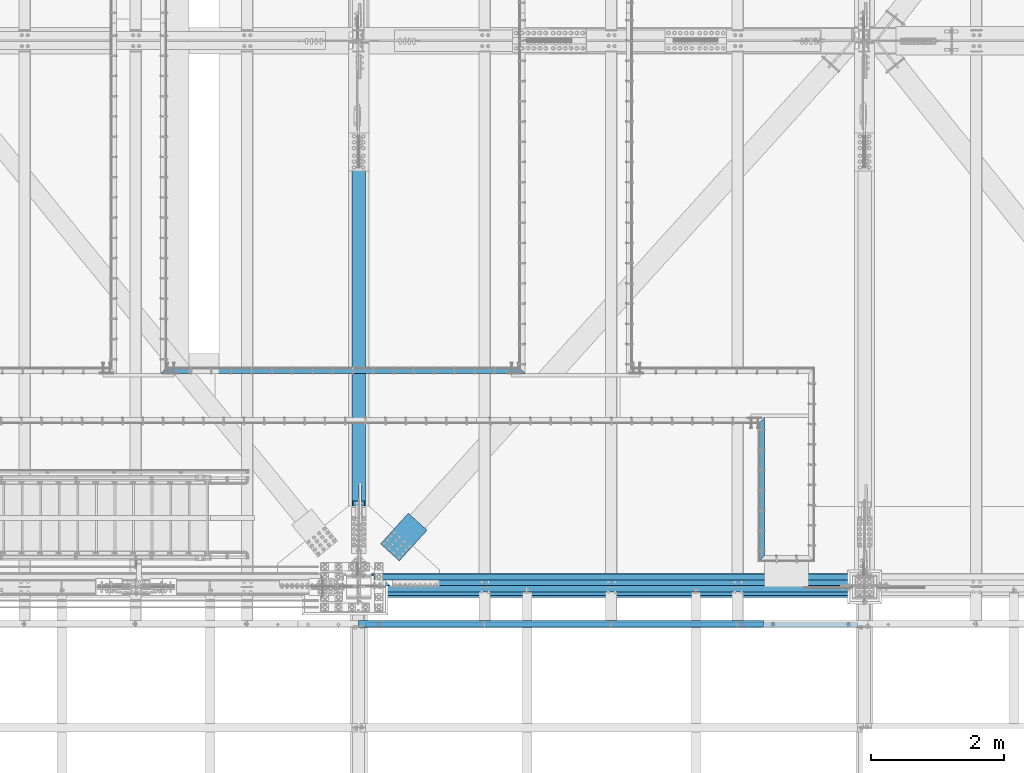
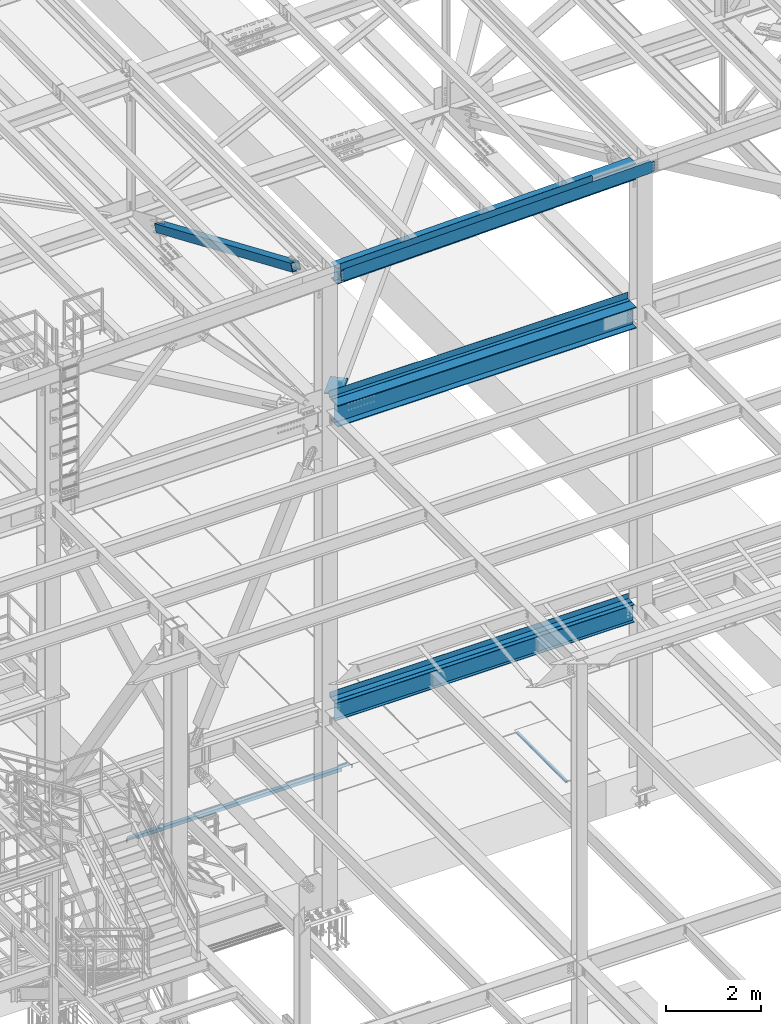
# One storey, part 1798 of 3843: 10 beams, 1 member, 9 elements without a shape of their own.
"""IFC2X3 building model written with IfcOpenShell, lengths in millimetres."""

from ifc_helpers import new_model, si_unit, frame, origin_with_axes, place, context, subcontext, project, spatial, faceted_brep, material, type_object, element, aggregate, save


model = new_model("IFC2X3")

# Units and contexts
model_context = context("Model", 3, precision=1e-05, world=origin_with_axes())
body_context = subcontext(model_context, "Body", "Model", "MODEL_VIEW")
ifc_project = project(units=[si_unit("LENGTHUNIT", "METRE", prefix="MILLI"), si_unit("AREAUNIT", "SQUARE_METRE"), si_unit("VOLUMEUNIT", "CUBIC_METRE"), si_unit("MASSUNIT", "GRAM", prefix="KILO"), si_unit("TIMEUNIT", "SECOND"), si_unit("PLANEANGLEUNIT", "RADIAN"), si_unit("SOLIDANGLEUNIT", "STERADIAN"), si_unit("THERMODYNAMICTEMPERATUREUNIT", "DEGREE_CELSIUS"), si_unit("LUMINOUSINTENSITYUNIT", "LUMEN")], contexts=[model_context])

# Site, building, storey
site_placement = place(None, origin_with_axes())
site = spatial("IfcSite", under=ifc_project, at=site_placement, CompositionType="ELEMENT")
building_placement = place(site_placement, origin_with_axes())
building = spatial("IfcBuilding", under=site, at=building_placement, Name="Undefined", CompositionType="ELEMENT")
storey_placement = place(building_placement, origin_with_axes())
storey = spatial("IfcBuildingStorey", under=building, at=storey_placement, Name="Undefined", CompositionType="ELEMENT", Elevation=0.0)

# Assembly, beam
assembly_1_placement = place(storey_placement, origin_with_axes())
assembly_1 = element("IfcElementAssembly", 1, at=assembly_1_placement, inside=storey, Name="EMBED_ANGLE", AssemblyPlace="NOTDEFINED", PredefinedType="RIGID_FRAME")
ifc_material_1 = material(Name="STEEL/A36")
beam_type_1 = type_object("IfcBeamType", Name="L3-1/2X3-1/2X5/16", PredefinedType="NOTDEFINED")
beam_1_placement = place(assembly_1_placement, frame((68707.7619595486, 26000.0749973387, 30410.15), z_axis=(0.0, 0.0, -1.0), x_axis=(0.0, 1.0, 0.0)))
beam_1 = element("IfcBeam", 2, at=beam_1_placement, type_object=beam_type_1, material=ifc_material_1, Name="EMBED_ANGLE", ObjectType="L3-1/2X3-1/2X5/16", context=body_context, shape_type="Brep", body=[
    faceted_brep([(88.8999999971129, 44.4500000000007, -44.4499999999971), (88.8999999965163, 44.4499999999971, 44.4500000000007), (2168.52499994361, 44.4499999956824, 44.4500000000007), (2168.52499994361, 44.4499999956824, -44.4500000000007), (80.9624999965163, 36.5124999999971, 44.4500000000007), (2160.58750050484, 36.5124999957043, 44.4500000000007), (80.9624999971129, 36.5125000000007, -36.5124999999971), (2160.58750050484, 36.5124999957043, -36.5125000000007), (3.63797880709171e-12, -44.4499999999971, -36.5125000000007), (2079.62500622933, -44.4500000041371, -36.5125000000007), (3.63797880709171e-12, -44.4499999999971, -44.4500000000007), (2079.62500622933, -44.4500000041371, -44.4500000000007)], [[[0, 1, 2, 3]], [[1, 4, 5, 2]], [[4, 6, 7, 5]], [[6, 8, 9, 7]], [[8, 10, 11, 9]], [[10, 0, 3, 11]], [[5, 7, 9, 11, 3, 2]], [[10, 8, 6, 4, 1, 0]]]),
])
aggregate(assembly_1, [beam_1])

assembly_2_placement = place(storey_placement, origin_with_axes())
assembly_2 = element("IfcElementAssembly", 3, at=assembly_2_placement, inside=storey, Name="EMBED_ANGLE", AssemblyPlace="NOTDEFINED", PredefinedType="RIGID_FRAME")
beam_2_placement = place(assembly_2_placement, frame((59652.662, 28873.45, 30410.15), z_axis=(0.0, 0.0, -1.0), x_axis=(1.0, 0.0, 0.0)))
beam_2 = element("IfcBeam", 4, at=beam_2_placement, type_object=beam_type_1, material=ifc_material_1, Name="EMBED_ANGLE", ObjectType="L3-1/2X3-1/2X5/16", context=body_context, shape_type="Brep", body=[
    faceted_brep([(44.4499023437311, 36.5125000000007, 44.4500000000007), (44.4499023437311, 36.5125000000007, -36.5125000000007), (44.4499023437311, 44.4500000000007, -36.5125000000007), (44.4499023437311, 44.4500000000007, 44.4500000000007), (260.349902343754, 36.5125000000007, -36.5125000000007), (260.349902343754, 44.4500000000007, -36.5125000000044), (260.349902343754, 36.5125000000007, 44.4499999999862), (260.349902343754, 44.4500000000007, 44.4500000000007), (5484.87605566408, 36.5125000000007, 44.4500000000007), (5492.81355566408, 44.4500000000007, 44.4500000000007), (5448.29999999998, 44.4500000000007, 44.4500000000007), (5448.29999999998, 36.5125000000007, 44.4499999999862), (5232.39999999996, 36.5125000000007, -36.5125000000007), (5232.39999999996, 36.5125000000007, 44.4500000000007), (5232.39999999996, 44.4500000000007, -36.5125000000007), (5232.39999999996, 44.4500000000007, 44.4500000000007), (5448.29999999998, 36.5125000000007, -36.5125000000007), (5448.29999999998, 44.4500000000007, -36.5125000000044), (5484.87605566408, 36.5125000000007, -36.5125000000007), (5232.39999999996, -44.4500000000007, -36.5125000000007), (260.349902343754, -44.4500000000007, -36.5125000000007), (88.9000039503298, -44.4500000001644, -36.5125000000007), (88.8999999971129, -44.4500000000007, -44.4499999999971), (5403.91355566408, -44.4500000000007, -44.4500000000007), (5403.91355566408, -44.4500000000007, -36.5125000000007), (44.4499023437311, 0.000101140303740976, -36.5125000000007), (7.93749960740388, 36.5125000000007, -36.5124999999825), (7.93750032749085, 36.5124999999825, 44.4500000000007), (-3.63797880709171e-12, 44.4499999999971, 44.4500000000007), (-3.63797880709171e-12, 44.4499999999971, -44.4500000000007), (5492.81355566408, 44.4500000000007, -44.4500000000007), (5448.29999999998, -0.0635556641063886, -36.5125000000007)], [[[0, 1, 2, 3]], [[4, 5, 2, 1]], [[6, 7, 5, 4]], [[8, 9, 10, 11]], [[12, 13, 6, 4]], [[13, 12, 14, 15]], [[16, 17, 14, 12]], [[11, 10, 17, 16]], [[18, 8, 11, 16]], [[19, 20, 21, 22, 23, 24]], [[22, 21, 25, 26, 27, 28, 29]], [[22, 29, 30, 23]], [[8, 18, 31, 24, 23, 30, 9]], [[16, 12, 4, 1, 26, 25, 21, 20, 19, 24, 31, 18]], [[27, 26, 1, 0]], [[28, 27, 0, 3]], [[15, 14, 17, 10, 9, 30, 29, 28, 3, 2, 5, 7]], [[13, 15, 7, 6]]]),
])
aggregate(assembly_2, [beam_2])

# Assembly, beams
assembly_3_placement = place(storey_placement, origin_with_axes())
assembly_3 = element("IfcElementAssembly", 5, at=assembly_3_placement, inside=storey, Name="BEAM", AssemblyPlace="NOTDEFINED", PredefinedType="RIGID_FRAME")
ifc_material_2 = material(Name="STEEL/A572-50")
beam_type_2 = type_object("IfcBeamType", Name="C12X20.7", PredefinedType="NOTDEFINED")
beam_3_placement = place(assembly_3_placement, frame((62633.0420977188, 25044.4000000694, 46128.4449733968), z_axis=(0.0211520550054438, 0.0, -0.999776270257025), x_axis=(0.999776270257024, 0.0, 0.0211520550054619)))
beam_3 = element("IfcBeam", 6, at=beam_3_placement, type_object=beam_type_2, material=ifc_material_2, Name="BEAM", ObjectType="C12X20.7", context=body_context, shape_type="Brep", body=[
    faceted_brep([(7523.28318920134, -38.1000000000058, -146.047459992216), (7523.28318920134, -38.1000000000058, -152.399999992194), (7523.28318920134, 38.1000000000058, -152.399999992194), (7523.28318920133, 38.1000000000058, -139.700000010889), (7523.28318920133, -1.12078851088881e-07, -139.700000010889), (7524.24991912393, 38.1000000000058, -134.839920492872), (7524.24991912393, 30.1625000000058, -134.674927492233), (7527.00293302441, 38.1000000000058, -130.71974402474), (7527.00293302441, 30.1625000000058, -130.71974402474), (7531.12310949257, 38.1000000000058, -127.966730124273), (7531.12310949257, 30.1625000000058, -127.966730124273), (7535.98318901064, 38.1000000000058, -127.000000201682), (7535.98318901064, 30.1625000000058, -127.000000201682), (7605.83052552149, 30.1625000000058, -127.000000201639), (7605.83021685822, 38.1000000000058, -127.000000201639), (7523.28318920102, -38.1000000000058, 146.047460007321), (7523.28318920101, -38.1000000000058, 152.400000007307), (98.4250003414782, -38.1000000000058, 152.399999999863), (98.4250003414927, -38.1000000000058, 146.047459999871), (7523.28318920101, 38.1000000000058, 152.400000007307), (98.4250003414782, 38.1000000000058, 152.399999999863), (98.4250003414927, 38.1000000000058, 139.699999784301), (98.4250003414927, 1.29402906168252e-06, 139.699999784301), (98.4250003417692, 1.00112811196595e-06, -139.699999832876), (98.4250003417692, 38.1000000000058, -139.699999832876), (98.4250003417837, 38.1000000000058, -152.399999999638), (98.4250003417837, -38.1000000000058, -152.399999999638), (98.4250003417765, -38.1000000000058, -146.047459999652), (97.458270419178, 30.1625000000058, -134.674927499669), (97.4582704191853, 38.1000000000058, -134.839920314858), (94.7052565187187, 30.1625000000058, -130.719743846734), (94.7052565187187, 38.1000000000058, -130.719743846734), (90.5850800505723, 30.1625000000058, -127.966729946267), (90.5850800505723, 38.1000000000058, -127.966729946267), (85.725000532555, 30.1625000000058, -127.000000023691), (85.725000532555, 38.1000000000058, -127.000000023691), (15.8752464537756, 30.1625000000058, -126.999999939733), (15.8750003662499, 38.1000000000058, -127.000000023749), (15.875251410529, 30.1624999999985, -114.300000648916), (15.8752465641373, 30.1624999999985, 116.299999344323), (15.8752517919565, 30.1625000000058, 127.000000059044), (15.8750006201954, 38.1000000000058, 126.999999975014), (85.7250005323076, 30.1625000000058, 126.99999997508), (85.7250005323076, 38.1000000000058, 126.99999997508), (90.5850800503176, 30.1625000000058, 127.966729897671), (90.5850800503176, 38.1000000000058, 127.966729897671), (94.7052565184495, 30.1625000000058, 130.719743798138), (94.7052565184495, 38.1000000000058, 130.719743798138), (97.4582704189161, 30.1625000000058, 134.674927499887), (97.4582704189233, 38.1000000000058, 134.839920266269), (7524.24991912362, 30.1625000000058, 134.674927507331), (7523.28318920104, 2.4073087843135e-06, 139.699999606266), (7523.28318920104, 38.1000000000058, 139.699999606266), (7524.24991912362, 38.1000000000058, 134.839920088249), (7527.00293302412, 30.1625000000058, 130.719743620124), (7527.00293302412, 38.1000000000058, 130.719743620124), (7531.12310949228, 30.1625000000058, 127.966729719657), (7531.12310949228, 38.1000000000058, 127.966729719657), (7535.98318901036, 30.1625000000058, 126.999999797081), (7535.98318901036, 38.1000000000058, 126.999999797081), (7605.83053466881, 30.1625000000058, 126.999999797132), (7605.83022600554, 38.1000000000058, 126.999999797139), (7605.83052579591, 30.1624999999985, 116.300000982046), (7605.83053410053, 30.1624999999985, -114.299999015653)], [[[0, 1, 2, 3, 4]], [[4, 3, 5, 6]], [[6, 5, 7, 8]], [[8, 7, 9, 10]], [[10, 9, 11, 12]], [[13, 12, 11, 14]], [[15, 16, 17, 18]], [[16, 19, 20, 17]], [[17, 20, 21, 22, 18]], [[23, 24, 25, 26, 27]], [[28, 29, 24, 23]], [[30, 31, 29, 28]], [[32, 33, 31, 30]], [[34, 35, 33, 32]], [[36, 37, 35, 34]], [[38, 39, 40, 41, 37, 36]], [[42, 43, 41, 40]], [[44, 45, 43, 42]], [[46, 47, 45, 44]], [[48, 49, 47, 46]], [[22, 21, 49, 48]], [[48, 50, 51, 15, 18, 22]], [[16, 15, 51, 52, 19]], [[50, 53, 52, 51]], [[54, 55, 53, 50]], [[56, 57, 55, 54]], [[58, 59, 57, 56]], [[60, 61, 59, 58]], [[61, 60, 62, 63, 13, 14]], [[31, 33, 35, 37, 41, 43, 45, 47, 49, 21, 20, 19, 52, 53, 55, 57, 59, 61, 14, 11, 9, 7, 5, 3, 2, 25, 24, 29]], [[2, 1, 26, 25]], [[1, 0, 27, 26]], [[0, 4, 6, 28, 23, 27]], [[63, 62, 60, 58, 56, 54, 50, 48, 46, 44, 42, 40, 39, 38, 36, 34, 32, 30, 28, 6, 8, 10, 12, 13]]]),
])
beam_type_3 = type_object("IfcBeamType", PredefinedType="NOTDEFINED")
beam_4_placement = place(assembly_3_placement, frame((65683.9814367119, 25107.8999968762, 46348.6029911897), z_axis=(0.999776270257024, 0.0, 0.0211520550054619), x_axis=(0.0, -1.0, 0.0)))
beam_4 = element("IfcBeam", 7, at=beam_4_placement, type_object=beam_type_3, material=ifc_material_1, Name="BENT_PLATE", context=body_context, shape_type="Brep", body=[
    faceted_brep([(-3.50355549016967e-07, -3.17499999742722, -3048.00000001723), (3.50421032635495e-07, -3.17500000260043, 3048.00000001724), (3.5035191103816e-07, 3.17499999739084, 3048.00000001724), (-3.50424670614302e-07, 3.17500000256405, -3048.00000001723), (101.599999864371, 3.17499999856227, 3048.00000000522), (101.599998739839, 3.17500000373548, -3048.00000002925), (95.249998765099, -3.17499999632128, -3048.00000002851), (95.2499998896274, -3.17500000149448, 3048.00000000597), (101.600000309205, -161.925000875126, 3047.9999999938), (101.599999608374, -161.925000446165, -3048.00000004067), (95.2500003092064, -161.925000900388, 3047.99999999456), (95.2499996083752, -161.925000471427, -3048.00000003992)], [[[0, 1, 2, 3]], [[3, 2, 4, 5]], [[1, 0, 6, 7]], [[5, 4, 8, 9]], [[4, 2, 1, 7, 10, 8]], [[7, 6, 11, 10]], [[6, 0, 3, 5, 9, 11]], [[10, 11, 9, 8]]]),
])
aggregate(assembly_3, [beam_4, beam_3])

# Assembly, beam
assembly_4_placement = place(storey_placement, origin_with_axes())
assembly_4 = element("IfcElementAssembly", 8, at=assembly_4_placement, inside=storey, Name="BEAM", AssemblyPlace="NOTDEFINED", PredefinedType="RIGID_FRAME")
ifc_material_3 = material(Name="STEEL/A992")
beam_type_4 = type_object("IfcBeamType", Name="W21X101", PredefinedType="NOTDEFINED")
beam_5_placement = place(assembly_4_placement, frame((62636.4, 25615.9, 42197.3375), z_axis=(0.0, 0.0, 1.0), x_axis=(1.0, 0.0, 0.0)))
beam_5 = element("IfcBeam", 9, at=beam_5_placement, type_object=beam_type_4, material=ifc_material_3, Name="BEAM", ObjectType="W21X101", context=body_context, shape_type="Brep", body=[
    faceted_brep([(7423.14999999999, 6.34999999999854, -250.824999999997), (7423.14999999999, 155.575000000001, -250.824999999997), (196.850000000006, 155.575000000001, -250.824999999997), (196.850000000006, 6.34999999999854, -250.824999999997), (7423.14999999999, -155.575000000001, -271.462500000001), (7423.14999999999, -155.575000000001, -250.824999999997), (196.850000000006, -155.575000000001, -250.824999999997), (196.850000000006, -155.575000000001, -271.462500000001), (7423.14999999999, 155.575000000001, -271.462500000001), (196.850000000006, 155.575000000001, -271.462500000001), (7423.14999999999, 6.34999999999854, 250.824999999997), (7423.14999999999, 155.575000000001, 250.824999999997), (7423.14999999999, 155.575000000001, 271.462500000001), (7423.14999999999, -155.575000000001, 271.462500000001), (7423.14999999999, -155.575000000001, 250.824999999997), (7423.14999999999, -6.34999999999854, 250.824999999997), (7423.14999999999, -6.34999999999854, -250.824999999997), (193.675000000003, 6.35000000000036, 250.428), (193.675000000003, -6.35000000000036, 250.428), (193.675000000003, -6.35000000000036, 250.824999999997), (193.675000000003, 6.35000000000036, 250.824999999997), (228.60000000002, 6.35000000000036, 250.428), (228.60000000002, -6.35000000000036, 250.428), (273.984905435093, 6.35000000000036, 234.406795689014), (273.984905435093, -6.35000000000036, 234.406795689014), (278.274267898814, 6.35000000000036, 231.347328818971), (278.274267898814, -6.35000000000036, 231.347328818971), (280.281122181914, 6.35000000000036, 226.475829690324), (280.281122181914, -6.35000000000036, 226.475829690324), (279.391438807783, 6.35000000000036, 221.282812131351), (279.391438807783, -6.35000000000036, 221.282812131351), (275.877430772234, 6.35000000000036, 217.357163726287), (275.877430772234, -6.35000000000036, 217.357163726287), (270.814265581474, 6.35000000000036, 215.900000000001), (270.814265581474, -6.35000000000036, 215.900000000001), (196.85001722983, 6.34999999999854, 215.900000000001), (196.85001722983, -6.34999999999854, 215.900000000001), (196.850000000006, -6.34999999999854, -250.824999999997), (193.675000000003, 155.575000000001, 250.824999999997), (205.589601116109, 155.575000000001, 271.462500000001), (205.589601116109, -155.575000000001, 271.462500000001), (193.675000000003, -155.575000000001, 250.824999999997)], [[[0, 1, 2, 3]], [[4, 5, 6, 7]], [[8, 4, 7, 9]], [[1, 8, 9, 2]], [[0, 10, 11, 12, 13, 14, 15, 16, 5, 4, 8, 1]], [[17, 18, 19, 20]], [[21, 22, 18, 17]], [[22, 21, 23, 24]], [[24, 23, 25, 26]], [[26, 25, 27, 28]], [[28, 27, 29, 30]], [[30, 29, 31, 32]], [[32, 31, 33, 34]], [[34, 33, 35, 36]], [[16, 15, 19, 18, 22, 24, 26, 28, 30, 32, 34, 36, 37]], [[5, 16, 37, 6]], [[36, 35, 3, 2, 9, 7, 6, 37]], [[33, 31, 29, 27, 25, 23, 21, 17, 20, 10, 0, 3, 35]], [[11, 10, 20, 38]], [[12, 11, 38, 39]], [[13, 12, 39, 40]], [[14, 13, 40, 41]], [[15, 14, 41, 19]], [[40, 39, 38, 20, 19, 41]]]),
])
aggregate(assembly_4, [beam_5])

assembly_5_placement = place(storey_placement, origin_with_axes())
assembly_5 = element("IfcElementAssembly", 10, at=assembly_5_placement, inside=storey, AssemblyPlace="NOTDEFINED", PredefinedType="RIGID_FRAME")
beam_type_5 = type_object("IfcBeamType", PredefinedType="NOTDEFINED")
beam_6_placement = place(assembly_5_placement, frame((63107.7669012129, 26137.1384847972, 42259.25), z_axis=(0.74169845569379, -0.670733479723091, 0.0), x_axis=(0.670733509108473, 0.741698429119972, 0.0)))
beam_6 = element("IfcBeam", 11, at=beam_6_placement, type_object=beam_type_5, material=ifc_material_2, Name="PLATE", context=body_context, shape_type="Brep", body=[
    faceted_brep([(5.85714587941766e-10, 12.6999999999971, -190.500000000349), (-6.14818418398499e-10, 12.6999999999971, 190.500000000364), (622.299987794569, 12.6999999999971, 190.499999998057), (622.299987793129, 12.6999999999971, -190.500000002765), (-6.14818418398499e-10, -12.6999999999971, 190.500000000364), (622.299987794569, -12.6999999999971, 190.499999998057), (5.85714587941766e-10, -12.6999999999971, -190.500000000349), (622.299987793129, -12.6999999999971, -190.500000002765)], [[[0, 1, 2, 3]], [[1, 4, 5, 2]], [[4, 6, 7, 5]], [[6, 0, 3, 7]], [[5, 7, 3, 2]], [[6, 4, 1, 0]]]),
])
aggregate(assembly_5, [beam_6])

# Assembly, member
assembly_6_placement = place(storey_placement, origin_with_axes())
assembly_6 = element("IfcElementAssembly", 12, at=assembly_6_placement, inside=storey, AssemblyPlace="NOTDEFINED", PredefinedType="RIGID_FRAME")
ifc_material_4 = material()
member_type = type_object("IfcMemberType", Name="HSS8X8X1/2", PredefinedType="NOTDEFINED")
member_placement = place(assembly_6_placement, frame((62636.4, 33845.5, 42259.1323534722), z_axis=(-1.0, 0.0, 0.0), x_axis=(0.0, -0.919173160691211, 0.393853653867689)))
member = element("IfcMember", 13, at=member_placement, type_object=member_type, material=ifc_material_4, ObjectType="HSS8X8X1/2", context=body_context, shape_type="Brep", body=[
    faceted_brep([(1364.28375243548, -101.599999994409, 17.4625000000015), (1364.28375243559, -88.8999999944626, 17.4625000000015), (1616.69625280701, -88.8999999935022, 17.4625000000015), (1616.69625280688, -101.599999993456, 17.4625000000015), (1623.37886209866, -88.8999999934804, 16.1332463655199), (1623.37886209856, -101.599999993434, 16.1332463655199), (1629.04410470369, -88.8999999934658, 12.3478522782025), (1629.04410470356, -101.599999993405, 12.3478522782025), (1632.82949879098, -88.899999993444, 6.68260967316746), (1632.82949879084, -101.59999999339, 6.68260967316746), (1616.69625280688, -101.599999993456, -17.4625000000015), (1616.69625280701, -88.8999999935022, -17.4625000000015), (1364.28375243559, -88.8999999944626, -17.4625000000015), (1364.28375243548, -101.599999994409, -17.4625000000015), (1623.37886209856, -101.599999993434, -16.1332463655199), (1623.37886209866, -88.8999999934804, -16.1332463655199), (1629.04410470356, -101.599999993405, -12.3478522782025), (1629.04410470369, -88.8999999934658, -12.3478522782025), (1632.82949879084, -101.59999999339, -6.68260967316746), (1632.82949879098, -88.899999993444, -6.68260967316746), (1634.15875242533, -101.599999993383, 3.81471181754023e-07), (1634.15875242547, -88.899999993444, 3.81471181754023e-07), (1364.28375243676, 88.9000000047981, 17.4625000000015), (1364.28375243685, 101.600000004752, 17.4625000000015), (1616.69625280882, 101.600000005705, 17.4625000000015), (1616.69625280872, 88.9000000057513, 17.4625000000015), (1623.37886210049, 101.600000005719, 16.1332463655199), (1623.37886210038, 88.9000000057804, 16.1332463655199), (1629.04410470549, 101.600000005748, 12.3478522782025), (1629.04410470539, 88.9000000057949, 12.3478522782025), (1632.82949879281, 101.600000005763, 6.68260967316746), (1632.82949879269, 88.9000000058168, 6.68260967316746), (1616.69625280872, 88.9000000057513, -17.4625000000015), (1616.69625280882, 101.600000005705, -17.4625000000015), (1364.28375243685, 101.600000004752, -17.4625000000015), (1364.28375243676, 88.9000000047981, -17.4625000000015), (1623.37886210038, 88.9000000057804, -16.1332463655199), (1623.37886210049, 101.600000005719, -16.1332463655199), (1629.04410470539, 88.9000000057949, -12.3478522782025), (1629.04410470549, 101.600000005748, -12.3478522782025), (1632.82949879269, 88.9000000058168, -6.68260967316746), (1632.82949879281, 101.600000005763, -6.68260967316746), (1634.15875242716, 88.900000005824, 3.81471181754023e-07), (1634.15875242728, 101.600000005777, 3.81471181754023e-07), (1364.28375243559, -88.8999999944626, 88.9000000000015), (1364.28375243676, 88.9000000047981, 88.9000000000015), (7586.19055475817, 88.9000000283941, 88.9000000000015), (7586.19055475698, -88.8999999708667, 88.9000000000015), (1364.28375243685, 101.600000004752, 101.599999999999), (7586.19055475826, 101.60000002834, 101.599999999999), (7586.19058824788, 101.599999969076, -6.34999999999854), (7333.778087826, 101.599999970109, -6.34999999999854), (7327.09547853428, 101.599999970131, -7.67925363448012), (7321.43023592923, 101.59999997016, -11.4646477217975), (7317.6448418419, 101.599999970174, -17.1298903268325), (7316.31558820741, 101.599999970174, -23.8125003814712), (7317.6448418419, 101.599999970174, -30.4951096731675), (7321.43023592923, 101.59999997016, -36.1603522782025), (7327.09547853428, 101.599999970131, -39.9457463655199), (7333.778087826, 101.599999970109, -41.2750000000015), (7586.19058824788, 101.599999969076, -41.2750000000015), (7586.19055475826, 101.60000002834, -101.599999999999), (1364.28375243685, 101.600000004752, -101.599999999999), (7586.19058824287, 88.8999999690568, -6.34999999999854), (7333.77808782098, 88.89999997009, -6.34999999999854), (7327.09547852926, 88.8999999701118, -7.67925363448012), (7321.4302359242, 88.8999999701409, -11.4646477217975), (7317.64484183687, 88.8999999701555, -17.1298903268325), (7316.31558820239, 88.8999999701628, -23.8125003814712), (7317.64484183687, 88.8999999701555, -30.4951096731675), (7321.4302359242, 88.8999999701409, -36.1603522782025), (7327.09547852926, 88.8999999701118, -39.9457463655199), (7333.77808782098, 88.89999997009, -41.2750000000015), (7586.19058824287, 88.8999999690568, -41.2750000000015), (1364.28375243676, 88.9000000047981, -88.9000000000015), (1364.28375243559, -88.8999999944626, -88.9000000000015), (7586.19055475698, -88.8999999708667, -88.9000000000015), (7586.19055475817, 88.9000000283941, -88.9000000000015), (7327.09547845395, -101.600000030099, -7.67925363448012), (7327.09547845897, -88.9000000300875, -7.67925363448012), (7333.77808775069, -88.9000000301166, -6.34999999999854), (7333.77808774567, -101.600000030136, -6.34999999999854), (7321.4302358489, -101.600000030077, -11.4646477217975), (7321.43023585392, -88.9000000300657, -11.4646477217975), (7317.64484176157, -101.600000030063, -17.1298903268325), (7317.64484176659, -88.9000000300512, -17.1298903268325), (7316.31558812708, -101.600000030056, -23.8125003814712), (7316.3155881321, -88.9000000300439, -23.8125003814712), (7317.64484176157, -101.600000030063, -30.4951096731675), (7317.64484176659, -88.9000000300512, -30.4951096731675), (7321.4302358489, -101.600000030077, -36.1603522782025), (7321.43023585392, -88.9000000300657, -36.1603522782025), (7327.09547845395, -101.600000030099, -39.9457463655199), (7327.09547845897, -88.9000000300875, -39.9457463655199), (7333.77808774567, -101.600000030136, -41.2750000000015), (7333.77808775069, -88.9000000301166, -41.2750000000015), (7586.19058816785, -101.600000031161, -41.2750000000015), (7586.19058817285, -88.9000000311571, -41.2750000000015), (7586.1905547569, -101.599999970813, -101.599999999999), (1364.28375243548, -101.599999994409, -101.599999999999), (7586.19058817285, -88.9000000311571, -6.34999999999854), (7586.19058816785, -101.600000031161, -6.34999999999854), (7586.1905547569, -101.599999970813, 101.599999999999), (1364.28375243548, -101.599999994409, 101.599999999999)], [[[0, 1, 2, 3]], [[3, 2, 4, 5]], [[5, 4, 6, 7]], [[7, 6, 8, 9]], [[10, 11, 12, 13]], [[14, 15, 11, 10]], [[16, 17, 15, 14]], [[18, 19, 17, 16]], [[20, 21, 19, 18]], [[9, 8, 21, 20]], [[22, 23, 24, 25]], [[25, 24, 26, 27]], [[27, 26, 28, 29]], [[29, 28, 30, 31]], [[32, 33, 34, 35]], [[36, 37, 33, 32]], [[38, 39, 37, 36]], [[40, 41, 39, 38]], [[42, 43, 41, 40]], [[31, 30, 43, 42]], [[44, 45, 46, 47]], [[28, 26, 24, 23, 48, 49, 50, 51, 52, 53, 54, 55, 56, 57, 58, 59, 60, 61, 62, 34, 33, 37, 39, 41, 43, 30]], [[63, 64, 51, 50]], [[65, 52, 51, 64]], [[66, 53, 52, 65]], [[67, 54, 53, 66]], [[68, 55, 54, 67]], [[69, 56, 55, 68]], [[70, 57, 56, 69]], [[71, 58, 57, 70]], [[72, 59, 58, 71]], [[73, 60, 59, 72]], [[74, 75, 76, 77]], [[78, 79, 80, 81]], [[82, 83, 79, 78]], [[84, 85, 83, 82]], [[86, 87, 85, 84]], [[88, 89, 87, 86]], [[90, 91, 89, 88]], [[92, 93, 91, 90]], [[94, 95, 93, 92]], [[96, 97, 95, 94]], [[98, 61, 60, 73, 77, 76, 97, 96]], [[99, 62, 61, 98]], [[75, 74, 35, 34, 62, 99, 13, 12]], [[6, 4, 2, 1, 44, 47, 100, 80, 79, 83, 85, 87, 89, 91, 93, 95, 97, 76, 75, 12, 11, 15, 17, 19, 21, 8]], [[101, 81, 80, 100]], [[47, 46, 63, 50, 49, 102, 101, 100]], [[48, 103, 102, 49]], [[16, 14, 10, 13, 99, 98, 96, 94, 92, 90, 88, 86, 84, 82, 78, 81, 101, 102, 103, 0, 3, 5, 7, 9, 20, 18]], [[103, 48, 23, 22, 45, 44, 1, 0]], [[38, 36, 32, 35, 74, 77, 73, 72, 71, 70, 69, 68, 67, 66, 65, 64, 63, 46, 45, 22, 25, 27, 29, 31, 42, 40]]]),
])
aggregate(assembly_6, [member])

# Assembly, beam
assembly_7_placement = place(storey_placement, origin_with_axes())
assembly_7 = element("IfcElementAssembly", 14, at=assembly_7_placement, inside=storey, Name="BENT_PLATE", AssemblyPlace="NOTDEFINED", PredefinedType="RIGID_FRAME")
beam_type_6 = type_object("IfcBeamType", PredefinedType="NOTDEFINED")
beam_7_placement = place(assembly_7_placement, frame((66444.8125, 25720.6749999977, 42471.975), z_axis=(-1.0, 0.0, 0.0), x_axis=(0.0, 1.0, 0.0)))
beam_7 = element("IfcBeam", 15, at=beam_7_placement, type_object=beam_type_6, material=ifc_material_1, Name="BENT_PLATE", context=body_context, shape_type="Brep", body=[
    faceted_brep([(66.6750000022803, -3.17500000000291, 3576.63750000002), (66.6750000022803, 3.17500000000291, 3576.63750000002), (0.0, 3.17500000000291, 3576.63750000003), (0.0, -3.17500000000291, 3576.63750000003), (66.6750000022766, -3.17500000000291, 3614.73750000001), (66.6750000022766, 3.17500000000291, 3614.7375), (92.075000002289, -3.17500000000291, -3614.7375), (0.0, -3.17500000000291, -3614.7375), (0.0, 3.17500000000291, -3614.7375), (98.4250000022876, 3.17500000000291, -3614.7375), (98.4250000022876, -161.924999997718, -3614.7375), (92.075000002289, -161.924999997718, -3614.7375), (98.4250000022876, 3.17500000000291, 3614.7375), (98.4250000022876, -161.924999997718, 3614.7375), (92.075000002289, -161.924999997718, 3614.7375), (92.075000002289, -3.17500000000291, 3614.7375)], [[[0, 1, 2, 3]], [[4, 5, 1, 0]], [[6, 7, 8, 9, 10, 11]], [[9, 12, 13, 10]], [[14, 11, 10, 13]], [[15, 6, 11, 14]], [[3, 7, 6, 15, 4, 0]], [[8, 7, 3, 2]], [[12, 9, 8, 2, 1, 5]], [[15, 14, 13, 12, 5, 4]]]),
])
aggregate(assembly_7, [beam_7])

# Assembly, beams
assembly_8_placement = place(storey_placement, origin_with_axes())
assembly_8 = element("IfcElementAssembly", 16, at=assembly_8_placement, inside=storey, Name="BEAM", AssemblyPlace="NOTDEFINED", PredefinedType="RIGID_FRAME")
beam_type_7 = type_object("IfcBeamType", PredefinedType="NOTDEFINED")
beam_8_placement = place(assembly_8_placement, frame((66446.4, 25641.3, 34813.875), z_axis=(-1.0, 0.0, 0.0), x_axis=(0.0, 1.0, 0.0)))
beam_8 = element("IfcBeam", 17, at=beam_8_placement, type_object=beam_type_7, material=ifc_material_1, Name="BENT_PLATE", context=body_context, shape_type="Brep", body=[
    faceted_brep([(0.0, -3.17500000000291, -3613.14999999999), (0.0, -3.17500000000291, 3613.15), (0.0, 3.17500000000291, 3613.15), (0.0, 3.17500000000291, -3613.14999999999), (152.399999999994, 3.17500000000291, 3613.15), (152.399999999994, 3.17500000000291, -3613.14999999999), (146.049999999996, -3.17500000000291, -3613.14999999999), (146.049999999996, -3.17500000000291, 3613.15), (152.399999999994, -136.524999999994, 3613.15), (152.399999999994, -136.524999999994, -3613.14999999999), (146.049999999996, -136.524999999994, 3613.15), (146.049999999996, -136.524999999994, -3613.14999999999)], [[[0, 1, 2, 3]], [[3, 2, 4, 5]], [[1, 0, 6, 7]], [[5, 4, 8, 9]], [[4, 2, 1, 7, 10, 8]], [[7, 6, 11, 10]], [[6, 0, 3, 5, 9, 11]], [[10, 11, 9, 8]]]),
])
beam_type_8 = type_object("IfcBeamType", Name="W18X35", PredefinedType="NOTDEFINED")
beam_9_placement = place(assembly_8_placement, frame((62636.4, 25615.9, 34585.275), z_axis=(0.0, 0.0, 1.0), x_axis=(1.0, 0.0, 0.0)))
beam_9 = element("IfcBeam", 18, at=beam_9_placement, type_object=beam_type_8, material=ifc_material_3, Name="BEAM", ObjectType="W18X35", context=body_context, shape_type="Brep", body=[
    faceted_brep([(196.849999999999, 76.2000000000007, -225.424999999999), (196.849999999999, 76.2000000000007, -214.3125), (7423.15000000001, 76.1999999999971, -214.3125), (7423.15000000001, 76.2000000000007, -225.425000000003), (196.849999999999, 3.96875, -214.3125), (7423.15000000001, 3.96875, -214.3125), (196.849999999999, 3.96875, 214.3125), (7423.15000000001, 3.96875, 214.3125), (196.849999999999, 76.2000000000007, 214.3125), (7423.15000000001, 76.1999999999971, 214.3125), (196.849999999999, 76.2000000000007, 225.425000000003), (7423.15000000001, 76.2000000000007, 225.425000000003), (196.849999999999, -76.2000000000007, 225.425000000003), (7423.15000000001, -76.2000000000007, 225.425000000003), (196.849999999999, -76.2000000000007, 214.3125), (7423.15000000001, -76.1999999999971, 214.3125), (196.849999999999, -3.96875, 214.3125), (7423.15000000001, -3.96875, 214.3125), (196.849999999999, -3.96875, -214.3125), (7423.15000000001, -3.96875, -214.3125), (196.849999999999, -76.2000000000007, -214.3125), (7423.15000000001, -76.1999999999971, -214.3125), (196.849999999999, -76.2000000000007, -225.424999999999), (7423.15000000001, -76.2000000000007, -225.425000000003)], [[[0, 1, 2, 3]], [[1, 4, 5, 2]], [[4, 6, 7, 5]], [[6, 8, 9, 7]], [[8, 10, 11, 9]], [[10, 12, 13, 11]], [[12, 14, 15, 13]], [[14, 16, 17, 15]], [[16, 18, 19, 17]], [[18, 20, 21, 19]], [[20, 22, 23, 21]], [[22, 0, 3, 23]], [[5, 7, 9, 11, 13, 15, 17, 19, 21, 23, 3, 2]], [[22, 20, 18, 16, 14, 12, 10, 8, 6, 4, 1, 0]]]),
])
aggregate(assembly_8, [beam_8, beam_9])

# Assembly, beam
assembly_9_placement = place(storey_placement, origin_with_axes())
assembly_9 = element("IfcElementAssembly", 19, at=assembly_9_placement, inside=storey, Name="BEAM", AssemblyPlace="NOTDEFINED", PredefinedType="RIGID_FRAME")
beam_type_9 = type_object("IfcBeamType", Name="W16X67", PredefinedType="NOTDEFINED")
beam_10_placement = place(assembly_9_placement, frame((62640.7988428852, 25615.9, 45761.8145292198), z_axis=(-0.0211520980073474, 0.0, 0.999776269347241), x_axis=(0.999776270257024, 0.0, 0.0211520550054619)))
beam_10 = element("IfcBeam", 20, at=beam_10_placement, type_object=beam_type_9, material=ifc_material_3, Name="BEAM", ObjectType="W16X67", context=body_context, shape_type="Brep", body=[
    faceted_brep([(188.094396478875, -130.174999999999, -207.962499999492), (188.094396478875, 130.174999999999, -207.962499999492), (7416.01150275391, 130.174999999999, -207.962499992216), (7416.01150275391, -130.174999999999, -207.962499992216), (188.463847647872, -130.174999999999, -190.49999999952), (188.463847647872, -4.76250000000073, -190.49999999952), (196.524600426201, -4.76250000000073, 190.499999999869), (196.524600426201, -130.174999999999, 190.499999999869), (196.894051595213, -130.174999999999, 207.962499999841), (196.894051595213, 130.174999999999, 207.962499999841), (196.524600426201, 130.174999999999, 190.499999999869), (196.524600426201, 4.76250000000073, 190.499999999869), (195.989385299312, 4.76250000000073, 165.202490022384), (189.242289076908, 4.76250000000073, -153.706144372954), (188.463847647872, 4.76250000000073, -190.49999999952), (188.463847647872, 130.174999999999, -190.49999999952), (7416.38095392293, -130.174999999999, -190.499999992237), (7416.38095392293, -4.76250000000073, -190.499999992237), (7424.4417067012, -4.76250000000073, 190.500000007152), (7424.4417067012, -130.174999999999, 190.500000007152), (7424.81115787019, -130.174999999999, 207.962500007125), (7424.81115787019, 130.174999999999, 207.962500007125), (7424.4417067012, 130.174999999999, 190.500000007152), (7424.4417067012, 4.76250000000073, 190.500000007152), (7423.86670778575, 4.76250000000073, 163.322068515161), (7417.11961156339, 4.76250000000073, -155.586565880192), (7416.38095392293, 4.76250000000073, -190.499999992237), (7416.38095392293, 130.174999999999, -190.499999992237)], [[[0, 1, 2, 3]], [[0, 4, 5, 6, 7, 8, 9, 10, 11, 12, 13, 14, 15, 1]], [[5, 4, 16, 17]], [[6, 5, 17, 18]], [[7, 6, 18, 19]], [[8, 7, 19, 20]], [[9, 8, 20, 21]], [[10, 9, 21, 22]], [[11, 10, 22, 23]], [[14, 13, 12, 11, 23, 24, 25, 26]], [[15, 14, 26, 27]], [[1, 15, 27, 2]], [[26, 25, 24, 23, 22, 21, 20, 19, 18, 17, 16, 3, 2, 27]], [[4, 0, 3, 16]]]),
])
aggregate(assembly_9, [beam_10])

save(model, "model.ifc")
